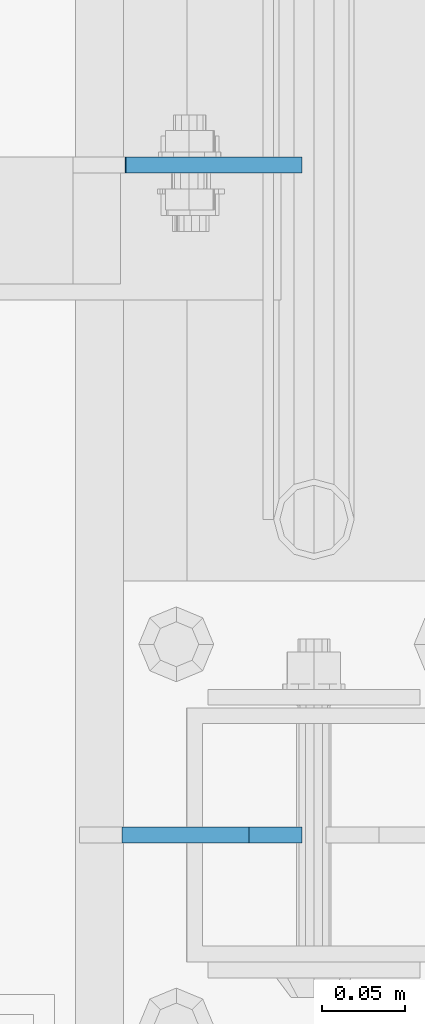
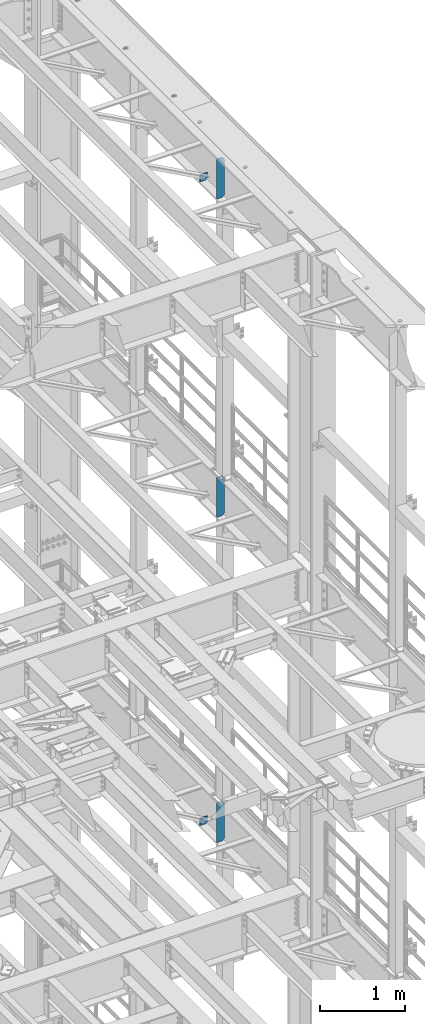
# One storey, part 1743 of 1876: 5 plates, 3 elements without a shape of their own.
"""IFC2X3 building model written with IfcOpenShell, lengths in millimetres."""

from ifc_helpers import new_model, si_unit, frame, origin_with_axes, place, context, subcontext, project, spatial, faceted_brep, material, type_object, element, aggregate, save


model = new_model("IFC2X3")

# Units and contexts
model_context = context("Model", 3, precision=1e-05, world=origin_with_axes())
body_context = subcontext(model_context, "Body", "Model", "MODEL_VIEW")
ifc_project = project(units=[si_unit("LENGTHUNIT", "METRE", prefix="MILLI"), si_unit("AREAUNIT", "SQUARE_METRE"), si_unit("VOLUMEUNIT", "CUBIC_METRE"), si_unit("MASSUNIT", "GRAM", prefix="KILO"), si_unit("TIMEUNIT", "SECOND"), si_unit("PLANEANGLEUNIT", "RADIAN"), si_unit("SOLIDANGLEUNIT", "STERADIAN"), si_unit("THERMODYNAMICTEMPERATUREUNIT", "DEGREE_CELSIUS"), si_unit("LUMINOUSINTENSITYUNIT", "LUMEN")], contexts=[model_context])

# Site, building, storey
site_placement = place(None, origin_with_axes())
site = spatial("IfcSite", under=ifc_project, at=site_placement, CompositionType="ELEMENT")
building_placement = place(site_placement, origin_with_axes())
building = spatial("IfcBuilding", under=site, at=building_placement, Name="Undefined", CompositionType="ELEMENT")
storey_placement = place(building_placement, origin_with_axes())
storey = spatial("IfcBuildingStorey", under=building, at=storey_placement, Name="Undefined", CompositionType="ELEMENT", Elevation=0.0)

# Assembly, plate
assembly_1_placement = place(storey_placement, origin_with_axes())
assembly_1 = element("IfcElementAssembly", 1, at=assembly_1_placement, inside=storey, Name="BEAM", AssemblyPlace="NOTDEFINED", PredefinedType="RIGID_FRAME")
ifc_material = material(Name="STEEL/A36")
plate_type_1 = type_object("IfcPlateType", PredefinedType="NOTDEFINED")
plate_1_placement = place(assembly_1_placement, frame((7612.85625, 10053.6375, 21958.3), z_axis=(0.0, 0.0, 1.0), x_axis=(-1.0, 0.0, 0.0)))
plate_1 = element("IfcPlate", 2, at=plate_1_placement, type_object=plate_type_1, material=ifc_material, Name="PLATE", context=body_context, shape_type="Brep", body=[
    faceted_brep([(-9.76996261670138e-14, -4.76250000000073, 31.75), (-3.4106151360902e-06, -4.76249999999982, 104.420860290527), (-3.4106151360902e-06, 4.76249999999982, 104.420860290527), (-9.76996261670138e-14, 4.76250000000073, 31.75), (105.552177429199, -4.76249999999982, 104.420860290527), (105.552177429199, 4.76249999999982, 104.420860290527), (105.552177429199, -4.76249999999982, 0.0), (105.552177429199, 4.76249999999982, 0.0), (31.75, -4.76250000000073, 0.0), (31.75, 4.76250000000073, 0.0)], [[[0, 1, 2, 3]], [[1, 4, 5, 2]], [[4, 6, 7, 5]], [[6, 8, 9, 7]], [[8, 0, 3, 9]], [[5, 7, 9, 3, 2]], [[8, 6, 4, 1, 0]]]),
])

assembly_2_placement = place(storey_placement, origin_with_axes())
assembly_2 = element("IfcElementAssembly", 3, at=assembly_2_placement, inside=storey, Name="BEAM", AssemblyPlace="NOTDEFINED", PredefinedType="RIGID_FRAME")
plate_type_2 = type_object("IfcPlateType", PredefinedType="NOTDEFINED")
plate_2_placement = place(assembly_2_placement, frame((7612.85625021727, 10053.6375, 12819.726415621), z_axis=(0.0, 0.0, -1.0), x_axis=(-1.0, 0.0, 0.0)))
plate_2 = element("IfcPlate", 4, at=plate_2_placement, type_object=plate_type_2, material=ifc_material, Name="PLATE", context=body_context, shape_type="Brep", body=[
    faceted_brep([(0.0, -4.76249999999982, 0.0), (-3.57139560946962e-06, -4.76249999999982, 81.6264114379865), (-3.57139560946962e-06, 4.76249999999982, 81.6264114379865), (0.0, 4.76249999999982, 0.0), (25.3999958038776, -4.76249999999982, 107.026412963854), (25.3999958038776, 4.76249999999982, 107.026412963854), (106.188095092818, -4.76249999999982, 107.02641296382), (106.188095092818, 4.76249999999982, 107.02641296382), (106.188095092773, -4.76249999999982, -7.27595761418343e-11), (106.188095092773, 4.76249999999982, -7.27595761418343e-11)], [[[0, 1, 2, 3]], [[1, 4, 5, 2]], [[4, 6, 7, 5]], [[6, 8, 9, 7]], [[8, 0, 3, 9]], [[5, 7, 9, 3, 2]], [[8, 6, 4, 1, 0]]]),
])

# Plate
plate_type_3 = type_object("IfcPlateType", PredefinedType="NOTDEFINED")
plate_3_placement = place(assembly_1_placement, frame((7612.85625, 9652.0, 21958.3), z_axis=(0.0, 0.0, 1.0), x_axis=(-1.0, 0.0, 0.0)))
plate_3 = element("IfcPlate", 5, at=plate_3_placement, type_object=plate_type_3, material=ifc_material, Name="PLATE", context=body_context, shape_type="Brep", body=[
    faceted_brep([(-9.76996261670138e-14, -4.76250000000073, 31.75), (0.0, -4.76249999999982, 539.75), (0.0, 4.76249999999982, 539.75), (-9.76996261670138e-14, 4.76250000000073, 31.75), (31.75, -4.76249999999982, 571.5), (31.75, 4.76249999999982, 571.5), (107.949996948242, -4.76249999999982, 571.5), (107.949996948242, 4.76249999999982, 571.5), (107.950006484985, -4.76250000000073, 0.0), (107.950006484985, 4.76250000000073, 0.0), (31.75, -4.76250000000073, 0.0), (31.75, 4.76250000000073, 0.0)], [[[0, 1, 2, 3]], [[1, 4, 5, 2]], [[4, 6, 7, 5]], [[6, 8, 9, 7]], [[8, 10, 11, 9]], [[10, 0, 3, 11]], [[5, 7, 9, 11, 3, 2]], [[10, 8, 6, 4, 1, 0]]]),
])

aggregate(assembly_1, [plate_3, plate_1])

# Assembly, plate
assembly_3_placement = place(storey_placement, origin_with_axes())
assembly_3 = element("IfcElementAssembly", 6, at=assembly_3_placement, inside=storey, Name="BEAM", AssemblyPlace="NOTDEFINED", PredefinedType="RIGID_FRAME")
plate_4_placement = place(assembly_3_placement, frame((7612.85624694824, 9652.0, 17386.3), z_axis=(0.0, 0.0, 1.0), x_axis=(-1.0, 0.0, 0.0)))
plate_4 = element("IfcPlate", 7, at=plate_4_placement, type_object=plate_type_3, material=ifc_material, Name="PLATE", context=body_context, shape_type="Brep", body=[
    faceted_brep([(-9.76996261670138e-14, -4.76250000000073, 31.75), (0.0, -4.76249999999982, 539.75), (0.0, 4.76249999999982, 539.75), (-9.76996261670138e-14, 4.76250000000073, 31.75), (31.75, -4.76249999999982, 571.5), (31.75, 4.76249999999982, 571.5), (107.949996948242, -4.76249999999982, 571.5), (107.949996948242, 4.76249999999982, 571.5), (107.950006484985, -4.76250000000073, 0.0), (107.950006484985, 4.76250000000073, 0.0), (31.75, -4.76250000000073, 0.0), (31.75, 4.76250000000073, 0.0)], [[[0, 1, 2, 3]], [[1, 4, 5, 2]], [[4, 6, 7, 5]], [[6, 8, 9, 7]], [[8, 10, 11, 9]], [[10, 0, 3, 11]], [[5, 7, 9, 11, 3, 2]], [[10, 8, 6, 4, 1, 0]]]),
])
aggregate(assembly_3, [plate_4])

# Plate
plate_5_placement = place(assembly_2_placement, frame((7612.85625, 9652.0, 12712.7), z_axis=(0.0, 0.0, 1.0), x_axis=(-1.0, 0.0, 0.0)))
plate_5 = element("IfcPlate", 8, at=plate_5_placement, type_object=plate_type_3, material=ifc_material, Name="PLATE", context=body_context, shape_type="Brep", body=[
    faceted_brep([(-9.76996261670138e-14, -4.76250000000073, 31.75), (0.0, -4.76249999999982, 539.75), (0.0, 4.76249999999982, 539.75), (-9.76996261670138e-14, 4.76250000000073, 31.75), (31.75, -4.76249999999982, 571.5), (31.75, 4.76249999999982, 571.5), (107.949996948242, -4.76249999999982, 571.5), (107.949996948242, 4.76249999999982, 571.5), (107.950006484985, -4.76250000000073, 0.0), (107.950006484985, 4.76250000000073, 0.0), (31.75, -4.76250000000073, 0.0), (31.75, 4.76250000000073, 0.0)], [[[0, 1, 2, 3]], [[1, 4, 5, 2]], [[4, 6, 7, 5]], [[6, 8, 9, 7]], [[8, 10, 11, 9]], [[10, 0, 3, 11]], [[5, 7, 9, 11, 3, 2]], [[10, 8, 6, 4, 1, 0]]]),
])

aggregate(assembly_2, [plate_2, plate_5])

save(model, "model.ifc")
